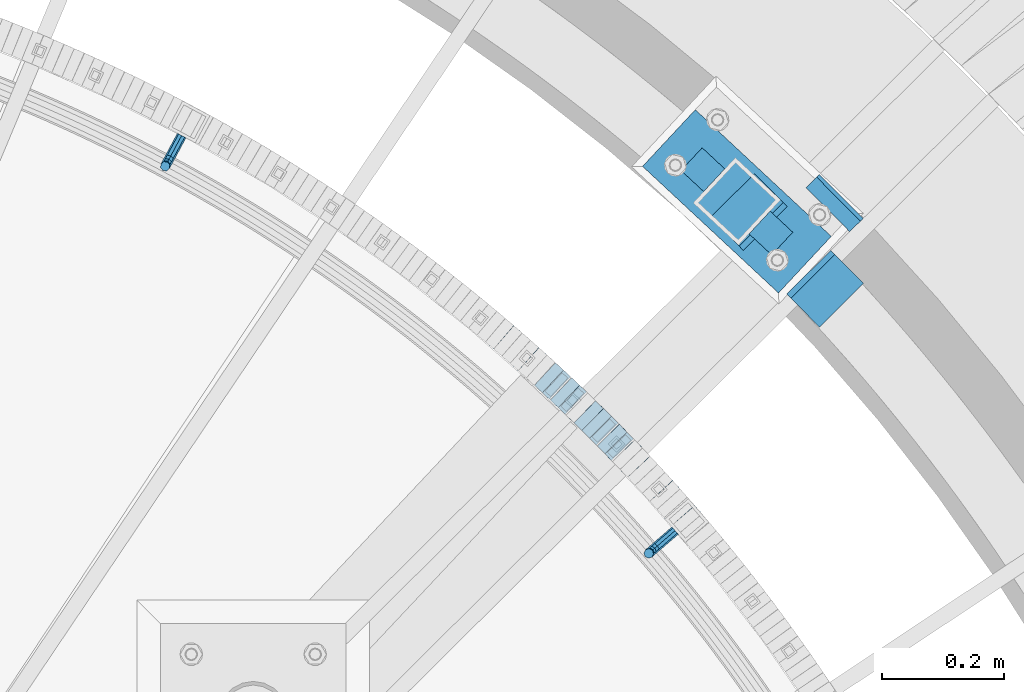
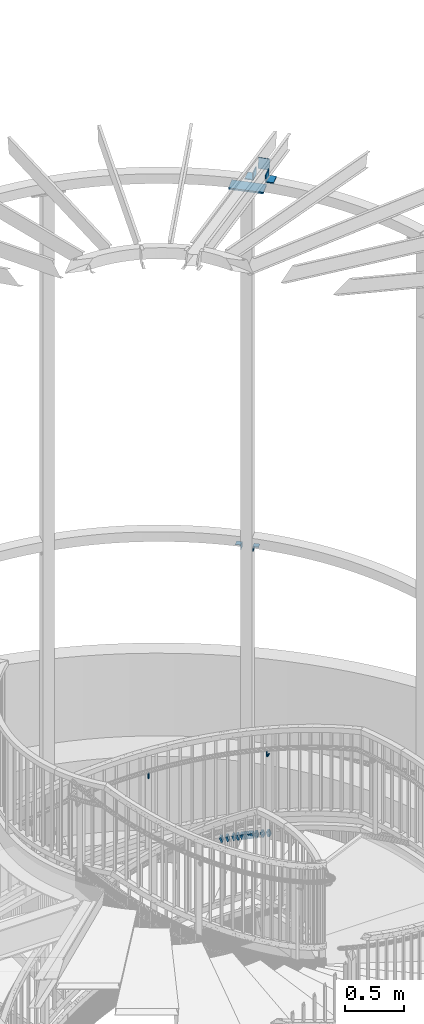
# One storey, part 510 of 975: 20 beams, 1 member.
"""IFC2X3 building model written with IfcOpenShell, lengths in millimetres."""

from ifc_helpers import new_model, si_unit, frame, origin_with_axes, place, context, subcontext, project, spatial, faceted_brep, material, type_object, element, save


model = new_model("IFC2X3")

# Units and contexts
model_context = context("Model", 3, precision=1e-05, world=origin_with_axes())
body_context = subcontext(model_context, "Body", "Model", "MODEL_VIEW")
ifc_project = project(units=[si_unit("LENGTHUNIT", "METRE", prefix="MILLI"), si_unit("AREAUNIT", "SQUARE_METRE"), si_unit("VOLUMEUNIT", "CUBIC_METRE"), si_unit("MASSUNIT", "GRAM", prefix="KILO"), si_unit("TIMEUNIT", "SECOND"), si_unit("PLANEANGLEUNIT", "RADIAN"), si_unit("SOLIDANGLEUNIT", "STERADIAN"), si_unit("THERMODYNAMICTEMPERATUREUNIT", "DEGREE_CELSIUS"), si_unit("LUMINOUSINTENSITYUNIT", "LUMEN")], contexts=[model_context])

# Site, building, storey
site_placement = place(None, origin_with_axes())
site = spatial("IfcSite", under=ifc_project, at=site_placement, CompositionType="ELEMENT")
building_placement = place(site_placement, origin_with_axes())
building = spatial("IfcBuilding", under=site, at=building_placement, Name="Undefined", CompositionType="ELEMENT")
storey_placement = place(building_placement, origin_with_axes())
storey = spatial("IfcBuildingStorey", under=building, at=storey_placement, Name="Undefined", CompositionType="ELEMENT", Elevation=0.0)

# Beams
ifc_material_1 = material(Name="STEEL/A36")
beam_type_1 = type_object("IfcBeamType", PredefinedType="NOTDEFINED")
beam_1_placement = place(storey_placement, frame((36887.3691172764, 5263.18102934092, 2660.88909571674), z_axis=(0.0, 0.0, 1.0), x_axis=(-0.757091853618418, -0.653308445670671, 0.0)))
element("IfcBeam", 1, at=beam_1_placement, inside=storey, type_object=beam_type_1, material=ifc_material_1, Name="BRACKET", context=body_context, shape_type="Brep", body=[
    faceted_brep([(-4.22995071858168e-07, -7.93750000000728, 0.0), (-2.99107341561466e-07, -5.61266007567065, -5.61266007566792), (31.7499842270954, -5.6126618385606, -5.6126600757234), (31.7499840980236, -7.93750176289177, -5.54791768081486e-11), (-1.09139364212751e-11, 1.81898940354586e-12, -7.9375), (31.7499845387247, -1.7628881323617e-06, -7.93750000005548), (2.99089151667431e-07, 5.61266007567428, -5.61266007566792), (31.7499848503612, 5.61265831278433, -5.6126600757234), (4.22980519942939e-07, 7.93750000001091, 0.0), (31.7499849794513, 7.93749823711914, -5.54791768081486e-11), (2.99089151667431e-07, 5.61266007567428, 5.61266007566792), (31.7499848503794, 5.61265831278433, 5.61266007561244), (-1.09139364212751e-11, 1.81898940354586e-12, 7.9375), (31.7499845387538, -1.7628881323617e-06, 7.93749999994452), (-2.99107341561466e-07, -5.61266007567065, 5.61266007566792), (31.7499842271172, -5.6126618385606, 5.61266007561244), (44.5076933192395, -2.47124626184814e-06, -5.39983394420233), (43.618015285665, -5.61266249752225, -3.25196192174644), (41.4701431341346, -7.93750230259684, 1.9334598451087), (39.322271240766, -5.61266225900181, 7.11888161196475), (38.432593830461, -2.1339365048334e-06, 9.26675363442064), (39.3222718640282, 5.61265789233948, 7.11888161196475), (41.4701440155623, 7.93749769741771, 1.9334598451087), (43.6180159089272, 5.61265765382268, -3.25196192174644), (53.6792468227941, 5.61265709518557, 3.47073764605557), (55.32315658683, -3.07176742353477e-06, 1.82682757038583), (49.7104969518768, 7.93749723988003, 7.43948764606012), (45.7417468228014, 5.61265753590487, 11.4082376460638), (44.0978364355033, -2.44848706643097e-06, 13.0521477217335), (45.7417461995356, -5.61266261544006, 11.4082376460638), (49.7104960704528, -7.93750276013816, 7.43948764606012), (53.6792461995283, -5.612663056163, 3.47073764605648), (60.4019463906188, 5.61265672191075, 13.5319685599115), (62.5498181014409, -3.47302193404175e-06, 12.6422908379673), (55.2165247528465, 7.93749693416248, 15.6798405823693), (50.0311028569122, 5.61265729774459, 17.8277126048279), (47.8832305228243, -2.65866765403189e-06, 18.7173903267721), (50.03110223365, -5.61266285360034, 17.8277126048279), (55.2165238714188, -7.93750306585207, 15.6798405823693), (60.4019457673567, -5.61266342943782, 13.5319685599115), (62.7626445446149, 5.61265659083438, 25.3999996184748), (65.0874841573168, -3.61392449121922e-06, 25.3999996184748), (57.1499845980288, 7.93749682680573, 25.3999996184748), (51.5373243932772, 5.61265721410746, 25.3999996184748), (49.2124841573132, -2.73247496807016e-06, 25.3999996184748), (51.5373237700151, -5.61266293723384, 25.3999996184748), (57.1499837166011, -7.93750317320519, 25.3999996184748), (62.7626439213527, -5.61266356051055, 25.3999996184748), (65.0874827799671, -8.13710357761011e-07, 63.5532656203741), (62.7626427854739, -5.61266086031537, 61.7133802904182), (57.1499826807376, -7.93750071448449, 60.9512776088477), (51.5373226341253, -5.61266071998034, 61.7133869906074), (49.2124827799453, -6.15244061918929e-07, 63.5532750958728), (51.5373227744385, 5.61265943136095, 65.3931604258296), (57.1499828791711, 7.93749928552643, 66.1552631073992), (62.7626429257907, 5.61265929102228, 65.3931537256394)], [[[0, 1, 2, 3]], [[1, 4, 5, 2]], [[4, 6, 7, 5]], [[6, 8, 9, 7]], [[8, 10, 11, 9]], [[10, 12, 13, 11]], [[12, 14, 15, 13]], [[14, 0, 3, 15]], [[14, 12, 10, 8, 6, 4, 1, 0]], [[2, 5, 16, 17]], [[3, 2, 17, 18]], [[15, 3, 18, 19]], [[13, 15, 19, 20]], [[11, 13, 20, 21]], [[9, 11, 21, 22]], [[7, 9, 22, 23]], [[5, 7, 23, 16]], [[23, 24, 25, 16]], [[22, 26, 24, 23]], [[21, 27, 26, 22]], [[20, 28, 27, 21]], [[19, 29, 28, 20]], [[18, 30, 29, 19]], [[17, 31, 30, 18]], [[16, 25, 31, 17]], [[24, 32, 33, 25]], [[26, 34, 32, 24]], [[27, 35, 34, 26]], [[28, 36, 35, 27]], [[29, 37, 36, 28]], [[30, 38, 37, 29]], [[31, 39, 38, 30]], [[25, 33, 39, 31]], [[32, 40, 41, 33]], [[34, 42, 40, 32]], [[35, 43, 42, 34]], [[36, 44, 43, 35]], [[37, 45, 44, 36]], [[38, 46, 45, 37]], [[39, 47, 46, 38]], [[33, 41, 47, 39]], [[47, 41, 48, 49]], [[46, 47, 49, 50]], [[45, 46, 50, 51]], [[44, 45, 51, 52]], [[43, 44, 52, 53]], [[42, 43, 53, 54]], [[40, 42, 54, 55]], [[41, 40, 55, 48]], [[54, 53, 52, 51, 50, 49, 48, 55]]]),
])
beam_2_placement = place(storey_placement, frame((36077.9622268555, 5911.18774239701, 2326.42423648715), z_axis=(0.0, 0.0, 1.0), x_axis=(-0.472681328114753, -0.881233432214004, 0.0)))
element("IfcBeam", 2, at=beam_2_placement, inside=storey, type_object=beam_type_1, material=ifc_material_1, Name="BRACKET", context=body_context, shape_type="Brep", body=[
    faceted_brep([(-4.22995071858168e-07, -7.93750000000728, 0.0), (-2.99107341561466e-07, -5.61266007567065, -5.61266007566792), (31.7499842270954, -5.6126618385606, -5.6126600757234), (31.7499840980236, -7.93750176289177, -5.54791768081486e-11), (-1.09139364212751e-11, 1.81898940354586e-12, -7.9375), (31.7499845387247, -1.7628881323617e-06, -7.93750000005548), (2.99089151667431e-07, 5.61266007567428, -5.61266007566792), (31.7499848503612, 5.61265831278433, -5.6126600757234), (4.22980519942939e-07, 7.93750000001091, 0.0), (31.7499849794513, 7.93749823711914, -5.54791768081486e-11), (2.99089151667431e-07, 5.61266007567428, 5.61266007566792), (31.7499848503794, 5.61265831278433, 5.61266007561244), (-1.09139364212751e-11, 1.81898940354586e-12, 7.9375), (31.7499845387538, -1.7628881323617e-06, 7.93749999994452), (-2.99107341561466e-07, -5.61266007567065, 5.61266007566792), (31.7499842271172, -5.6126618385606, 5.61266007561244), (44.5076933192395, -2.47124626184814e-06, -5.39983394420233), (43.618015285665, -5.61266249752225, -3.25196192174644), (41.4701431341346, -7.93750230259684, 1.9334598451087), (39.322271240766, -5.61266225900181, 7.11888161196475), (38.432593830461, -2.1339365048334e-06, 9.26675363442064), (39.3222718640282, 5.61265789233948, 7.11888161196475), (41.4701440155623, 7.93749769741771, 1.9334598451087), (43.6180159089272, 5.61265765382268, -3.25196192174644), (53.6792468227941, 5.61265709518557, 3.47073764605557), (55.32315658683, -3.07176742353477e-06, 1.82682757038583), (49.7104969518768, 7.93749723988003, 7.43948764606012), (45.7417468228014, 5.61265753590487, 11.4082376460638), (44.0978364355033, -2.44848706643097e-06, 13.0521477217335), (45.7417461995356, -5.61266261544006, 11.4082376460638), (49.7104960704528, -7.93750276013816, 7.43948764606012), (53.6792461995283, -5.612663056163, 3.47073764605648), (60.4019463906188, 5.61265672191075, 13.5319685599115), (62.5498181014409, -3.47302193404175e-06, 12.6422908379673), (55.2165247528465, 7.93749693416248, 15.6798405823693), (50.0311028569122, 5.61265729774459, 17.8277126048279), (47.8832305228243, -2.65866765403189e-06, 18.7173903267721), (50.03110223365, -5.61266285360034, 17.8277126048279), (55.2165238714188, -7.93750306585207, 15.6798405823693), (60.4019457673567, -5.61266342943782, 13.5319685599115), (62.7626445446149, 5.61265659083438, 25.3999996184748), (65.0874841573168, -3.61392449121922e-06, 25.3999996184748), (57.1499845980288, 7.93749682680573, 25.3999996184748), (51.5373243932772, 5.61265721410746, 25.3999996184748), (49.2124841573132, -2.73247496807016e-06, 25.3999996184748), (51.5373237700151, -5.61266293723384, 25.3999996184748), (57.1499837166011, -7.93750317320519, 25.3999996184748), (62.7626439213527, -5.61266356051055, 25.3999996184748), (65.0874827799671, -8.13710357761011e-07, 63.5532656203741), (62.7626427854739, -5.61266086031537, 61.7133802904182), (57.1499826807376, -7.93750071448449, 60.9512776088477), (51.5373226341253, -5.61266071998034, 61.7133869906074), (49.2124827799453, -6.15244061918929e-07, 63.5532750958728), (51.5373227744385, 5.61265943136095, 65.3931604258296), (57.1499828791711, 7.93749928552643, 66.1552631073992), (62.7626429257907, 5.61265929102228, 65.3931537256394)], [[[0, 1, 2, 3]], [[1, 4, 5, 2]], [[4, 6, 7, 5]], [[6, 8, 9, 7]], [[8, 10, 11, 9]], [[10, 12, 13, 11]], [[12, 14, 15, 13]], [[14, 0, 3, 15]], [[14, 12, 10, 8, 6, 4, 1, 0]], [[2, 5, 16, 17]], [[3, 2, 17, 18]], [[15, 3, 18, 19]], [[13, 15, 19, 20]], [[11, 13, 20, 21]], [[9, 11, 21, 22]], [[7, 9, 22, 23]], [[5, 7, 23, 16]], [[23, 24, 25, 16]], [[22, 26, 24, 23]], [[21, 27, 26, 22]], [[20, 28, 27, 21]], [[19, 29, 28, 20]], [[18, 30, 29, 19]], [[17, 31, 30, 18]], [[16, 25, 31, 17]], [[24, 32, 33, 25]], [[26, 34, 32, 24]], [[27, 35, 34, 26]], [[28, 36, 35, 27]], [[29, 37, 36, 28]], [[30, 38, 37, 29]], [[31, 39, 38, 30]], [[25, 33, 39, 31]], [[32, 40, 41, 33]], [[34, 42, 40, 32]], [[35, 43, 42, 34]], [[36, 44, 43, 35]], [[37, 45, 44, 36]], [[38, 46, 45, 37]], [[39, 47, 46, 38]], [[33, 41, 47, 39]], [[47, 41, 48, 49]], [[46, 47, 49, 50]], [[45, 46, 50, 51]], [[44, 45, 51, 52]], [[43, 44, 52, 53]], [[42, 43, 53, 54]], [[40, 42, 54, 55]], [[41, 40, 55, 48]], [[54, 53, 52, 51, 50, 49, 48, 55]]]),
])
ifc_material_2 = material()
beam_type_2 = type_object("IfcBeamType", Name="HSS2X2X.188_TUBES", PredefinedType="NOTDEFINED")
beam_3_placement = place(storey_placement, frame((36905.5241545854, 5281.95459966641, 1822.74259521614), z_axis=(-0.7504912652109, -0.660880368025971, 7.65489858167714e-11), x_axis=(-0.628549392664893, 0.713776428619664, -0.308948006835376)))
element("IfcBeam", 3, at=beam_3_placement, inside=storey, type_object=beam_type_2, material=ifc_material_2, Name="WALL", ObjectType="HSS2X2X.188_TUBES", context=body_context, shape_type="Brep", body=[
    faceted_brep([(0.0, 20.6374999999753, -20.6375000000298), (0.0, -20.6375000000153, -20.6375000000153), (18.767258723612, -20.6375000000025, -20.6374999999862), (18.7672587236229, 20.6374999999953, -20.637499999968), (0.0, -20.6374999999825, 20.6375000000335), (18.767258723612, -20.6375000000135, 20.6375000000153), (0.0, 20.6375000000116, 20.6375000000189), (18.7672587236266, 20.6374999999844, 20.6375000000371), (0.0, 25.3999999999724, -25.4000000000342), (0.0, 25.400000000016, 25.4000000000196), (18.7672587236302, 25.3999999999814, 25.4000000000342), (18.7672587236229, 25.399999999996, -25.3999999999687), (0.0, -25.399999999976, 25.4000000000378), (18.7672587236157, -25.4000000000142, 25.400000000016), (0.0, -25.400000000016, -25.4000000000196), (18.767258723612, -25.4000000000015, -25.3999999999905)], [[[0, 1, 2, 3]], [[1, 4, 5, 2]], [[4, 6, 7, 5]], [[6, 0, 3, 7]], [[8, 9, 10, 11]], [[9, 12, 13, 10]], [[12, 14, 15, 13]], [[14, 8, 11, 15]], [[13, 15, 11, 10], [5, 7, 3, 2]], [[14, 12, 9, 8], [6, 4, 1, 0]]]),
])
beam_4_placement = place(storey_placement, frame((36869.6880162256, 5322.55142669597, 1805.53594078418), z_axis=(-0.737154140248161, -0.675724628465615, -1.81907807927928e-10), x_axis=(-0.642844486019874, 0.701284894021618, -0.308140332009512)))
element("IfcBeam", 4, at=beam_4_placement, inside=storey, type_object=beam_type_2, material=ifc_material_2, Name="WALL", ObjectType="HSS2X2X.188_TUBES", context=body_context, shape_type="Brep", body=[
    faceted_brep([(0.0, 20.6374999999753, -20.6375000000298), (0.0, -20.6375000000153, -20.6375000000153), (18.8225928075335, -20.6374999999935, -20.6375000000298), (18.8225928075699, 20.6374999999898, -20.6374999999825), (0.0, -20.6374999999825, 20.6375000000335), (18.8225928075772, -20.637500000008, 20.6375000000226), (0.0, 20.6375000000116, 20.6375000000189), (18.8225928076135, 20.6374999999753, 20.6375000000698), (0.0, 25.3999999999724, -25.4000000000342), (0.0, 25.400000000016, 25.4000000000196), (18.8225928076281, 25.3999999999705, 25.4000000000815), (18.8225928075663, 25.3999999999905, -25.3999999999796), (0.0, -25.399999999976, 25.4000000000378), (18.8225928075808, -25.4000000000087, 25.4000000000233), (0.0, -25.400000000016, -25.4000000000196), (18.8225928075226, -25.3999999999905, -25.4000000000378)], [[[0, 1, 2, 3]], [[1, 4, 5, 2]], [[4, 6, 7, 5]], [[6, 0, 3, 7]], [[8, 9, 10, 11]], [[9, 12, 13, 10]], [[12, 14, 15, 13]], [[14, 8, 11, 15]], [[13, 15, 11, 10], [5, 7, 3, 2]], [[14, 12, 9, 8], [6, 4, 1, 0]]]),
])
for number, where, z_axis, x_axis, name in (
    (5, (36833.1078564508, 5362.32625578201, 1788.33723010588), (-0.726393020235017, -0.68727955022236, 0.0), (-0.653802268984162, 0.691010527983319, -0.30829700499255), "WALL"),
    (6, (36808.2204446262, 5388.59982707633, 1776.83794755947), (-0.715441150972862, -0.698672998973502, 0.0), (-0.664621009862621, 0.680571913859264, -0.308384148936238), "WALL"),
):
    element("IfcBeam", number, at=place(storey_placement, frame(where, z_axis=z_axis, x_axis=x_axis)), inside=storey, type_object=beam_type_2, material=ifc_material_2, Name=name, ObjectType="HSS2X2X.188_TUBES", context=body_context, shape_type="Brep", body=[
        faceted_brep([(0.0, 20.6374999999753, -20.6375000000298), (0.0, -20.6375000000153, -20.6375000000153), (18.8066477608099, -20.6374999999862, -20.6375000000116), (18.8066477608172, 20.6375000000062, -20.6374999999971), (0.0, -20.6374999999825, 20.6375000000335), (18.8066477608463, -20.6375000000062, 20.6375000000407), (0.0, 20.6375000000116, 20.6375000000189), (18.8066477608536, 20.6374999999844, 20.637500000048), (0.0, 25.3999999999724, -25.4000000000342), (0.0, 25.400000000016, 25.4000000000196), (18.8066477608591, 25.3999999999814, 25.400000000056), (18.8066477608154, 25.4000000000051, -25.4000000000015), (0.0, -25.399999999976, 25.4000000000378), (18.8066477608518, -25.4000000000087, 25.4000000000451), (0.0, -25.400000000016, -25.4000000000196), (18.8066477608081, -25.3999999999851, -25.4000000000196)], [[[0, 1, 2, 3]], [[1, 4, 5, 2]], [[4, 6, 7, 5]], [[6, 0, 3, 7]], [[8, 9, 10, 11]], [[9, 12, 13, 10]], [[12, 14, 15, 13]], [[14, 8, 11, 15]], [[13, 15, 11, 10], [5, 7, 3, 2]], [[14, 12, 9, 8], [6, 4, 1, 0]]]),
    ])
beam_5_placement = place(storey_placement, frame((36795.6348521604, 5401.48747376124, 1770.99857530389), z_axis=(-0.715441150972862, -0.698672998973502, 0.0), x_axis=(-0.665704015149624, 0.681680911153087, -0.303561031068164)))
element("IfcBeam", 7, at=beam_5_placement, inside=storey, type_object=beam_type_2, material=ifc_material_2, Name="WALL", ObjectType="HSS2X2X.188_TUBES", context=body_context, shape_type="Brep", body=[
    faceted_brep([(0.0, 20.6374999999753, -20.6375000000298), (0.0, -20.6375000000153, -20.6375000000153), (18.7771137292038, -20.637500000008, -20.6374999999862), (18.777113729182, 20.6375000000062, -20.6375000000189), (0.0, -20.6374999999825, 20.6375000000335), (18.7771137291729, -20.6374999999916, 20.6374999999753), (0.0, 20.6375000000116, 20.6375000000189), (18.7771137291529, 20.6375000000207, 20.6374999999389), (0.0, 25.3999999999724, -25.4000000000342), (0.0, 25.400000000016, 25.4000000000196), (18.7771137291475, 25.4000000000251, 25.3999999999287), (18.7771137291857, 25.4000000000051, -25.4000000000196), (0.0, -25.399999999976, 25.4000000000378), (18.7771137291711, -25.3999999999905, 25.3999999999724), (0.0, -25.400000000016, -25.4000000000196), (18.7771137292129, -25.4000000000124, -25.3999999999724)], [[[0, 1, 2, 3]], [[1, 4, 5, 2]], [[4, 6, 7, 5]], [[6, 0, 3, 7]], [[8, 9, 10, 11]], [[9, 12, 13, 10]], [[12, 14, 15, 13]], [[14, 8, 11, 15]], [[13, 15, 11, 10], [5, 7, 3, 2]], [[14, 12, 9, 8], [6, 4, 1, 0]]]),
])
beam_6_placement = place(storey_placement, frame((36782.9690367759, 5414.58510422188, 1765.28996345008), z_axis=(-0.707106781186548, -0.707106781186548, 0.0), x_axis=(-0.67397956792407, 0.67397956792407, -0.302494766965922)))
element("IfcBeam", 8, at=beam_6_placement, inside=storey, type_object=beam_type_2, material=ifc_material_2, Name="WALL", ObjectType="HSS2X2X.188_TUBES", context=body_context, shape_type="Brep", body=[
    faceted_brep([(0.0, 20.6374999999753, -20.6375000000298), (0.0, -20.6375000000153, -20.6375000000153), (18.8433011969464, -20.6374999999898, -20.6375000000226), (18.8433011969719, 20.6375000000007, -20.6374999999862), (0.0, -20.6374999999825, 20.6375000000335), (18.8433011969828, -20.6375000000044, 20.6375000000189), (0.0, 20.6375000000116, 20.6375000000189), (18.8433011970155, 20.6374999999862, 20.6375000000517), (0.0, 25.3999999999724, -25.4000000000342), (0.0, 25.400000000016, 25.4000000000196), (18.8433011970228, 25.3999999999833, 25.4000000000597), (18.8433011969719, 25.4000000000015, -25.3999999999869), (0.0, -25.399999999976, 25.4000000000378), (18.8433011969864, -25.4000000000051, 25.4000000000196), (0.0, -25.400000000016, -25.4000000000196), (18.8433011969391, -25.3999999999869, -25.4000000000269)], [[[0, 1, 2, 3]], [[1, 4, 5, 2]], [[4, 6, 7, 5]], [[6, 0, 3, 7]], [[8, 9, 10, 11]], [[9, 12, 13, 10]], [[12, 14, 15, 13]], [[14, 8, 11, 15]], [[13, 15, 11, 10], [5, 7, 3, 2]], [[14, 12, 9, 8], [6, 4, 1, 0]]]),
])
beam_7_placement = place(storey_placement, frame((36770.3258464131, 5427.27180061259, 1759.63809114998), z_axis=(-0.704306391484569, -0.709896124030822, -1.04486844065832e-10), x_axis=(-0.675293128015495, 0.669975860015393, -0.30840158600708)))
element("IfcBeam", 9, at=beam_7_placement, inside=storey, type_object=beam_type_2, material=ifc_material_2, Name="WALL", ObjectType="HSS2X2X.188_TUBES", context=body_context, shape_type="Brep", body=[
    faceted_brep([(0.0, 20.6374999999753, -20.6375000000298), (0.0, -20.6375000000153, -20.6375000000153), (18.8066477608099, -20.6374999999862, -20.6375000000116), (18.8066477608172, 20.6375000000062, -20.6374999999971), (0.0, -20.6374999999825, 20.6375000000335), (18.8066477608463, -20.6375000000062, 20.6375000000407), (0.0, 20.6375000000116, 20.6375000000189), (18.8066477608536, 20.6374999999844, 20.637500000048), (0.0, 25.3999999999724, -25.4000000000342), (0.0, 25.400000000016, 25.4000000000196), (18.8066477608591, 25.3999999999814, 25.400000000056), (18.8066477608154, 25.4000000000051, -25.4000000000015), (0.0, -25.399999999976, 25.4000000000378), (18.8066477608518, -25.4000000000087, 25.4000000000451), (0.0, -25.400000000016, -25.4000000000196), (18.8066477608081, -25.3999999999851, -25.4000000000196)], [[[0, 1, 2, 3]], [[1, 4, 5, 2]], [[4, 6, 7, 5]], [[6, 0, 3, 7]], [[8, 9, 10, 11]], [[9, 12, 13, 10]], [[12, 14, 15, 13]], [[14, 8, 11, 15]], [[13, 15, 11, 10], [5, 7, 3, 2]], [[14, 12, 9, 8], [6, 4, 1, 0]]]),
])
beam_8_placement = place(storey_placement, frame((36757.5565781819, 5439.98336300254, 1753.8290034237), z_axis=(-0.701517264855551, -0.712652458853252, 0.0), x_axis=(-0.67817008520287, 0.667573677199723, -0.307295820091931)))
element("IfcBeam", 10, at=beam_8_placement, inside=storey, type_object=beam_type_2, material=ifc_material_2, Name="WALL", ObjectType="HSS2X2X.188_TUBES", context=body_context, shape_type="Brep", body=[
    faceted_brep([(0.0, 20.6374999999753, -20.6375000000298), (0.0, -20.6375000000153, -20.6375000000153), (18.8653120832787, -20.6374999999989, -20.6374999999935), (18.8653120832823, 20.6374999999971, -20.6374999999935), (0.0, -20.6374999999825, 20.6375000000335), (18.8653120833151, -20.6375000000116, 20.6375000000298), (0.0, 20.6375000000116, 20.6375000000189), (18.8653120833151, 20.6374999999844, 20.6375000000298), (0.0, 25.3999999999724, -25.4000000000342), (0.0, 25.400000000016, 25.4000000000196), (18.8653120833187, 25.3999999999814, 25.4000000000378), (18.8653120832823, 25.3999999999942, -25.3999999999905), (0.0, -25.399999999976, 25.4000000000378), (18.8653120833187, -25.4000000000124, 25.4000000000342), (0.0, -25.400000000016, -25.4000000000196), (18.8653120832787, -25.3999999999978, -25.3999999999942)], [[[0, 1, 2, 3]], [[1, 4, 5, 2]], [[4, 6, 7, 5]], [[6, 0, 3, 7]], [[8, 9, 10, 11]], [[9, 12, 13, 10]], [[12, 14, 15, 13]], [[14, 8, 11, 15]], [[13, 15, 11, 10], [5, 7, 3, 2]], [[14, 12, 9, 8], [6, 4, 1, 0]]]),
])
beam_9_placement = place(storey_placement, frame((36744.6382311008, 5452.74267482182, 1747.99857530369), z_axis=(-0.698672998973502, -0.715441150972862, 0.0), x_axis=(-0.681680911153151, 0.665704015149541, -0.3035610310682)))
element("IfcBeam", 11, at=beam_9_placement, inside=storey, type_object=beam_type_2, material=ifc_material_2, Name="WALL", ObjectType="HSS2X2X.188_TUBES", context=body_context, shape_type="Brep", body=[
    faceted_brep([(0.0, 20.6374999999753, -20.6375000000298), (0.0, -20.6375000000153, -20.6375000000153), (18.7771137292038, -20.637500000008, -20.6374999999862), (18.777113729182, 20.6375000000062, -20.6375000000189), (0.0, -20.6374999999825, 20.6375000000335), (18.7771137291729, -20.6374999999916, 20.6374999999753), (0.0, 20.6375000000116, 20.6375000000189), (18.7771137291529, 20.6375000000207, 20.6374999999389), (0.0, 25.3999999999724, -25.4000000000342), (0.0, 25.400000000016, 25.4000000000196), (18.7771137291475, 25.4000000000251, 25.3999999999287), (18.7771137291857, 25.4000000000051, -25.4000000000196), (0.0, -25.399999999976, 25.4000000000378), (18.7771137291711, -25.3999999999905, 25.3999999999724), (0.0, -25.400000000016, -25.4000000000196), (18.7771137292129, -25.4000000000124, -25.3999999999724)], [[[0, 1, 2, 3]], [[1, 4, 5, 2]], [[4, 6, 7, 5]], [[6, 0, 3, 7]], [[8, 9, 10, 11]], [[9, 12, 13, 10]], [[12, 14, 15, 13]], [[14, 8, 11, 15]], [[13, 15, 11, 10], [5, 7, 3, 2]], [[14, 12, 9, 8], [6, 4, 1, 0]]]),
])
beam_10_placement = place(storey_placement, frame((36718.8206618746, 5477.92602549841, 1736.6372301054), z_axis=(-0.68727955022236, -0.726393020235017, 0.0), x_axis=(-0.691010527983282, 0.653802268984202, -0.308297004992549)))
element("IfcBeam", 12, at=beam_10_placement, inside=storey, type_object=beam_type_2, material=ifc_material_2, Name="WALL", ObjectType="HSS2X2X.188_TUBES", context=body_context, shape_type="Brep", body=[
    faceted_brep([(0.0, 20.6374999999753, -20.6375000000298), (0.0, -20.6375000000153, -20.6375000000153), (18.8066477608099, -20.6374999999862, -20.6375000000116), (18.8066477608172, 20.6375000000062, -20.6374999999971), (0.0, -20.6374999999825, 20.6375000000335), (18.8066477608463, -20.6375000000062, 20.6375000000407), (0.0, 20.6375000000116, 20.6375000000189), (18.8066477608536, 20.6374999999844, 20.637500000048), (0.0, 25.3999999999724, -25.4000000000342), (0.0, 25.400000000016, 25.4000000000196), (18.8066477608591, 25.3999999999814, 25.400000000056), (18.8066477608154, 25.4000000000051, -25.4000000000015), (0.0, -25.399999999976, 25.4000000000378), (18.8066477608518, -25.4000000000087, 25.4000000000451), (0.0, -25.400000000016, -25.4000000000196), (18.8066477608081, -25.3999999999851, -25.4000000000196)], [[[0, 1, 2, 3]], [[1, 4, 5, 2]], [[4, 6, 7, 5]], [[6, 0, 3, 7]], [[8, 9, 10, 11]], [[9, 12, 13, 10]], [[12, 14, 15, 13]], [[14, 8, 11, 15]], [[13, 15, 11, 10], [5, 7, 3, 2]], [[14, 12, 9, 8], [6, 4, 1, 0]]]),
])
beam_11_placement = place(storey_placement, frame((36692.6154420113, 5502.60960347912, 1725.1366567412), z_axis=(-0.681521706605876, -0.731797897937001, 7.8165840022848e-11), x_axis=(-0.696168654216239, 0.648340273201414, -0.308227343095751)))
element("IfcBeam", 13, at=beam_11_placement, inside=storey, type_object=beam_type_2, material=ifc_material_2, Name="WALL", ObjectType="HSS2X2X.188_TUBES", context=body_context, shape_type="Brep", body=[
    faceted_brep([(0.0, 20.6374999999753, -20.6375000000298), (0.0, -20.6375000000153, -20.6375000000153), (18.8225928075335, -20.6374999999935, -20.6375000000298), (18.8225928075699, 20.6374999999898, -20.6374999999825), (0.0, -20.6374999999825, 20.6375000000335), (18.8225928075772, -20.637500000008, 20.6375000000226), (0.0, 20.6375000000116, 20.6375000000189), (18.8225928076135, 20.6374999999753, 20.6375000000698), (0.0, 25.3999999999724, -25.4000000000342), (0.0, 25.400000000016, 25.4000000000196), (18.8225928076281, 25.3999999999705, 25.4000000000815), (18.8225928075663, 25.3999999999905, -25.3999999999796), (0.0, -25.399999999976, 25.4000000000378), (18.8225928075808, -25.4000000000087, 25.4000000000233), (0.0, -25.400000000016, -25.4000000000196), (18.8225928075226, -25.3999999999905, -25.4000000000378)], [[[0, 1, 2, 3]], [[1, 4, 5, 2]], [[4, 6, 7, 5]], [[6, 0, 3, 7]], [[8, 9, 10, 11]], [[9, 12, 13, 10]], [[12, 14, 15, 13]], [[14, 8, 11, 15]], [[13, 15, 11, 10], [5, 7, 3, 2]], [[14, 12, 9, 8], [6, 4, 1, 0]]]),
])
beam_12_placement = place(storey_placement, frame((36652.6895217547, 5539.35626907059, 1707.93408316944), z_axis=(-0.664017424017672, -0.747717099310251, 6.23961113888072e-11), x_axis=(-0.711388553004374, 0.63175550600376, -0.307914448001838)))
element("IfcBeam", 14, at=beam_12_placement, inside=storey, type_object=beam_type_2, material=ifc_material_2, Name="WALL", ObjectType="HSS2X2X.188_TUBES", context=body_context, shape_type="Brep", body=[
    faceted_brep([(0.0, 20.6374999999753, -20.6375000000298), (0.0, -20.6375000000153, -20.6375000000153), (18.8433011969464, -20.6374999999898, -20.6375000000226), (18.8433011969719, 20.6375000000007, -20.6374999999862), (0.0, -20.6374999999825, 20.6375000000335), (18.8433011969828, -20.6375000000044, 20.6375000000189), (0.0, 20.6375000000116, 20.6375000000189), (18.8433011970155, 20.6374999999862, 20.6375000000517), (0.0, 25.3999999999724, -25.4000000000342), (0.0, 25.400000000016, 25.4000000000196), (18.8433011970228, 25.3999999999833, 25.4000000000597), (18.8433011969719, 25.4000000000015, -25.3999999999869), (0.0, -25.399999999976, 25.4000000000378), (18.8433011969864, -25.4000000000051, 25.4000000000196), (0.0, -25.400000000016, -25.4000000000196), (18.8433011969391, -25.3999999999869, -25.4000000000269)], [[[0, 1, 2, 3]], [[1, 4, 5, 2]], [[4, 6, 7, 5]], [[6, 0, 3, 7]], [[8, 9, 10, 11]], [[9, 12, 13, 10]], [[12, 14, 15, 13]], [[14, 8, 11, 15]], [[13, 15, 11, 10], [5, 7, 3, 2]], [[14, 12, 9, 8], [6, 4, 1, 0]]]),
])
beam_13_placement = place(storey_placement, frame((36612.1231947212, 5575.19546375389, 1690.73999687726), z_axis=(-0.648946606014645, -0.760833952017175, 0.0), x_axis=(-0.723690971170934, 0.617265828145817, -0.308632914072897)))
element("IfcBeam", 15, at=beam_13_placement, inside=storey, type_object=beam_type_2, material=ifc_material_2, Name="WALL", ObjectType="HSS2X2X.188_TUBES", context=body_context, shape_type="Brep", body=[
    faceted_brep([(0.0, 20.6374999999753, -20.6375000000298), (0.0, -20.6375000000153, -20.6375000000153), (18.7853666454903, -20.6375000000535, -20.6375000000326), (18.785366645363, 20.6374999999862, -20.6375000000044), (0.0, -20.6374999999825, 20.6375000000335), (18.785366645352, -20.6375000000007, 20.6374999999989), (0.0, 20.6375000000116, 20.6375000000189), (18.7853666453102, 20.6375000000025, 20.6374999999753), (0.0, 25.3999999999724, -25.4000000000342), (0.0, 25.400000000016, 25.4000000000196), (18.7853666452065, 25.4000000000451, 25.4000000000351), (18.7853666453739, 25.3999999999833, -25.400000000006), (0.0, -25.399999999976, 25.4000000000378), (18.7853666497213, -25.399999993424, 25.3999999995158), (0.0, -25.400000000016, -25.4000000000196), (18.7853666455194, -25.4000000000633, -25.4000000000406)], [[[0, 1, 2, 3]], [[1, 4, 5, 2]], [[4, 6, 7, 5]], [[6, 0, 3, 7]], [[8, 9, 10, 11]], [[9, 12, 13, 10]], [[12, 14, 15, 13]], [[14, 8, 11, 15]], [[13, 15, 11, 10], [5, 7, 3, 2]], [[14, 12, 9, 8], [6, 4, 1, 0]]]),
])
beam_type_3 = type_object("IfcBeamType", Name="L2X2X1/4", PredefinedType="NOTDEFINED")
for number, where, z_axis, x_axis, name in (
    (16, (37027.1755243208, 5732.75246008767, 4445.0), (0.73176109614993, -0.68156122113971, 0.0), (0.68156122113971, 0.73176109614993, 0.0), "ANGLE"),
    (17, (36950.2784433014, 5873.79585387377, 4445.0), (-0.73176109614993, 0.68156122113971, 0.0), (-0.68156122113971, -0.73176109614993, 0.0), "ANGLE"),
):
    element("IfcBeam", number, at=place(storey_placement, frame(where, z_axis=z_axis, x_axis=x_axis)), inside=storey, type_object=beam_type_3, material=ifc_material_1, Name=name, ObjectType="L2X2X1/4", context=body_context, shape_type="Brep", body=[
        faceted_brep([(0.0, 25.3999999999724, -25.4000000000342), (0.0, 25.400000000016, 25.4000000000196), (50.8000000000102, 25.3999999999996, 25.4000000000015), (50.7999999999411, 25.3999999999996, -25.4000000000487), (3.27418092638254e-11, 19.0500000000002, 25.4000000000269), (50.8000000000102, 19.0500000000002, 25.4000000000015), (-2.5465851649642e-11, 19.0500000000002, -19.0500000000211), (50.7999999999483, 19.0500000000002, -19.0500000000429), (-2.5465851649642e-11, -25.3999999999996, -19.0500000000211), (50.7999999999483, -25.3999999999996, -19.0500000000429), (0.0, -25.400000000016, -25.4000000000196), (50.7999999999411, -25.3999999999996, -25.4000000000487)], [[[0, 1, 2, 3]], [[1, 4, 5, 2]], [[4, 6, 7, 5]], [[6, 8, 9, 7]], [[8, 10, 11, 9]], [[10, 0, 3, 11]], [[5, 7, 9, 11, 3, 2]], [[10, 8, 6, 4, 1, 0]]]),
    ])
beam_type_4 = type_object("IfcBeamType", Name="L3X3X3/8", PredefinedType="NOTDEFINED")
for number, where, z_axis, x_axis, name in (
    (18, (36972.2542837232, 5750.09120297776, 8318.5), (-0.704511181200153, 0.709692888201625, 9.99996585988633e-10), (0.709692888126235, 0.704511181276098, 5.71968485019169e-10), "ANGLE"),
    (19, (37169.3931431699, 5695.71586139416, 8318.5), (0.704511181200146, -0.709692888201633, 9.99996585983236e-10), (-0.709692888126233, -0.7045111812761, 5.71955752093346e-10), "ANGLE"),
):
    element("IfcBeam", number, at=place(storey_placement, frame(where, z_axis=z_axis, x_axis=x_axis)), inside=storey, type_object=beam_type_4, material=ifc_material_1, Name=name, ObjectType="L3X3X3/8", context=body_context, shape_type="Brep", body=[
        faceted_brep([(-6.18456397205591e-11, 38.0999999999876, -38.1000000000258), (1.45519152283669e-10, 38.1000000000295, 38.1000000000386), (101.599999999788, 38.1000000000004, 38.0999999999767), (101.599999999762, 38.1000000000004, -38.1000000000313), (4.72937244921923e-11, 28.5749999999316, 38.1), (101.599999999788, 28.5750000000007, 38.0999999999767), (4.72937244921923e-11, 28.5749999999316, -28.575), (101.599999999766, 28.5750000000007, -28.5750000000298), (-5.0931703299284e-11, -38.0999999999112, -28.575), (101.599999999766, -38.1000000000004, -28.5750000000298), (-1.41881173476577e-10, -38.1000000000258, -38.1000000000386), (101.599999999762, -38.1000000000004, -38.1000000000313)], [[[0, 1, 2, 3]], [[1, 4, 5, 2]], [[4, 6, 7, 5]], [[6, 8, 9, 7]], [[8, 10, 11, 9]], [[10, 0, 3, 11]], [[5, 7, 9, 11, 3, 2]], [[10, 8, 6, 4, 1, 0]]]),
    ])

# Member
member_type = type_object("IfcMemberType", PredefinedType="NOTDEFINED")
member_placement = place(storey_placement, frame((37140.1353020326, 5791.67094501686, 8306.8139839197), z_axis=(-0.704511181200153, 0.709692888201625, 9.99996585988633e-10), x_axis=(0.17213026717781, 0.170873527176511, 0.970140922150774)))
element("IfcMember", 20, at=member_placement, inside=storey, type_object=member_type, material=ifc_material_1, Name="PLATE", context=body_context, shape_type="Brep", body=[
    faceted_brep([(0.0, 3.17499999999927, -50.7999999999993), (0.0, 3.17499999999109, 50.7999992370678), (101.600000000738, 3.17500000004657, 50.7999999999374), (101.600000000827, 3.17500000007567, -50.800000000112), (0.0, -3.17500000000882, 50.7999992370605), (101.60000000074, -3.17499999995562, 50.7999999999411), (0.0, -3.17499999999927, -50.7999999999993), (101.60000000083, -3.17499999993379, -50.8000000001084)], [[[0, 1, 2, 3]], [[1, 4, 5, 2]], [[4, 6, 7, 5]], [[6, 0, 3, 7]], [[5, 7, 3, 2]], [[6, 4, 1, 0]]]),
])

# Beam
beam_type_5 = type_object("IfcBeamType", PredefinedType="NOTDEFINED")
beam_14_placement = place(storey_placement, frame((36877.2065927595, 5907.14408708075, 8170.8625), z_axis=(-0.68156122113971, -0.73176109614993, 0.0), x_axis=(0.73176109614993, -0.68156122113971, 0.0)))
element("IfcBeam", 21, at=beam_14_placement, inside=storey, type_object=beam_type_5, material=ifc_material_1, Name="PLATE", context=body_context, shape_type="Brep", body=[
    faceted_brep([(0.0, 7.9375, -63.5), (0.0, 7.9375, 63.5), (304.799999999529, 7.9375, 63.5), (304.799999999529, 7.9375, -63.5), (0.0, -7.9375, 63.5), (304.799999999529, -7.9375, 63.5), (0.0, -7.9375, -63.5), (304.799999999529, -7.9375, -63.5)], [[[0, 1, 2, 3]], [[1, 4, 5, 2]], [[4, 6, 7, 5]], [[6, 0, 3, 7]], [[5, 7, 3, 2]], [[6, 4, 1, 0]]]),
])

save(model, "model.ifc")
